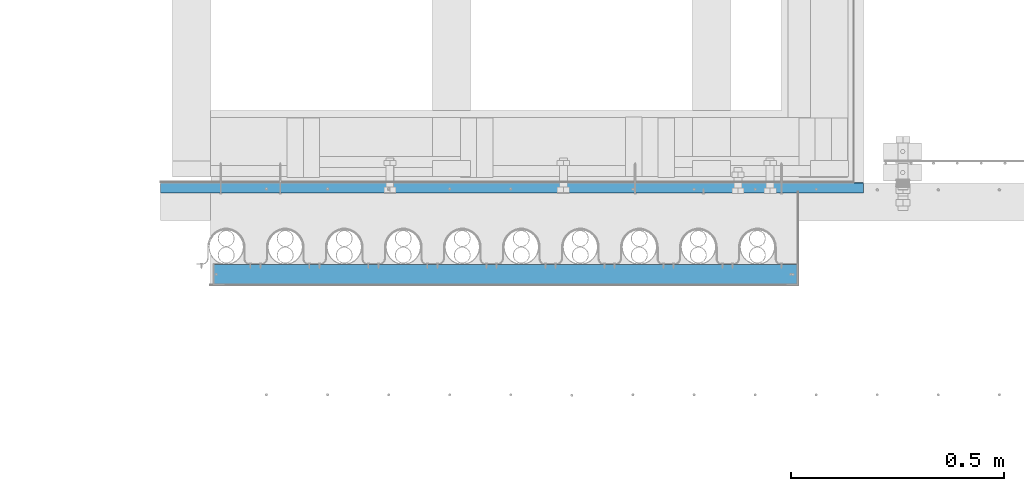
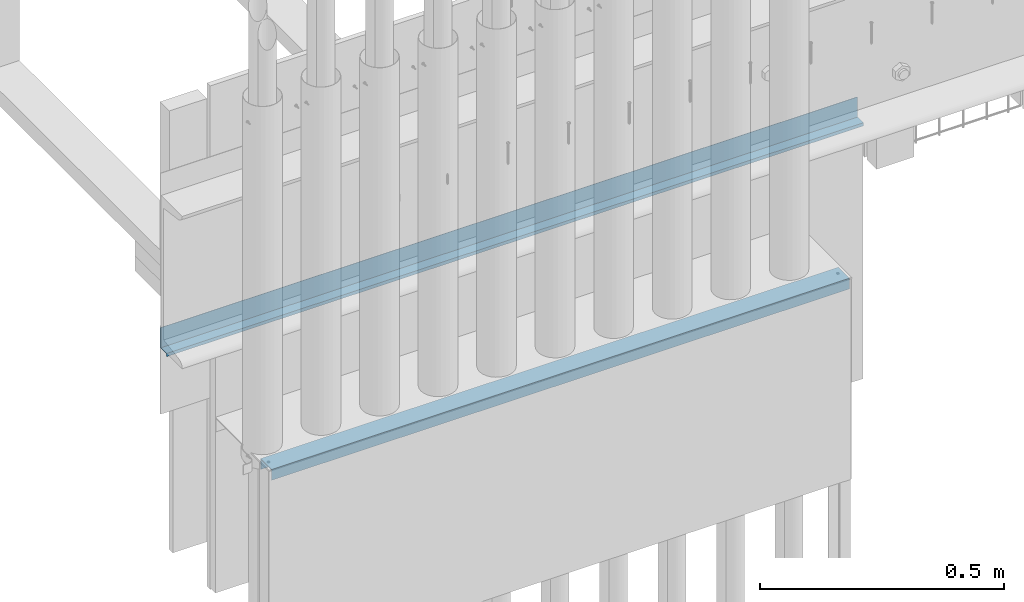
# One storey, part 5 of 44: 2 walls.
"""IFC4 building model written with IfcOpenShell, lengths in feet."""

from ifc_helpers import new_model, entity, si_unit, converted_unit, derived_unit, direction, frame, origin, place, context, subcontext, project, spatial, material, type_object, element, save


model = new_model("IFC4")

# Units and contexts
model_context = context("Model", 3, precision=0.0001, world=origin(), true_north=direction((6.12303176911189e-17, 1.0)))
body_context = subcontext(model_context, "Body", "Model", "MODEL_VIEW")
ifc_project = project(units=[converted_unit("LENGTHUNIT", "FOOT", entity("IfcRatioMeasure", 0.3048), si_unit("LENGTHUNIT", "METRE"), dimensions=[1, 0, 0, 0, 0, 0, 0]), converted_unit("AREAUNIT", "SQUARE FOOT", entity("IfcRatioMeasure", 0.09290304), si_unit("AREAUNIT", "SQUARE_METRE"), dimensions=[2, 0, 0, 0, 0, 0, 0]), converted_unit("VOLUMEUNIT", "CUBIC FOOT", entity("IfcRatioMeasure", 0.028316846592), si_unit("VOLUMEUNIT", "CUBIC_METRE"), dimensions=[3, 0, 0, 0, 0, 0, 0]), converted_unit("PLANEANGLEUNIT", "DEGREE", entity("IfcRatioMeasure", 0.0174532925199433), si_unit("PLANEANGLEUNIT", "RADIAN"), dimensions=[0, 0, 0, 0, 0, 0, 0]), si_unit("MASSUNIT", "GRAM", prefix="KILO"), derived_unit("MASSDENSITYUNIT", [(si_unit("MASSUNIT", "GRAM", prefix="KILO"), 1), (si_unit("LENGTHUNIT", "METRE"), -3)]), derived_unit("MOMENTOFINERTIAUNIT", [(si_unit("LENGTHUNIT", "METRE"), 4)]), si_unit("TIMEUNIT", "SECOND"), si_unit("FREQUENCYUNIT", "HERTZ"), si_unit("THERMODYNAMICTEMPERATUREUNIT", "DEGREE_CELSIUS"), derived_unit("THERMALTRANSMITTANCEUNIT", [(si_unit("MASSUNIT", "GRAM", prefix="KILO"), 1), (si_unit("THERMODYNAMICTEMPERATUREUNIT", "KELVIN"), -1), (si_unit("TIMEUNIT", "SECOND"), -3)]), derived_unit("VOLUMETRICFLOWRATEUNIT", [(si_unit("LENGTHUNIT", "METRE"), 3), (si_unit("TIMEUNIT", "SECOND"), -1)]), si_unit("ELECTRICCURRENTUNIT", "AMPERE"), si_unit("ELECTRICVOLTAGEUNIT", "VOLT"), si_unit("POWERUNIT", "WATT"), si_unit("FORCEUNIT", "NEWTON"), si_unit("ILLUMINANCEUNIT", "LUX"), si_unit("LUMINOUSFLUXUNIT", "LUMEN"), si_unit("LUMINOUSINTENSITYUNIT", "CANDELA"), derived_unit("USERDEFINED", [(si_unit("MASSUNIT", "GRAM", prefix="KILO"), -1), (si_unit("LENGTHUNIT", "METRE"), -2), (si_unit("TIMEUNIT", "SECOND"), 3), (si_unit("LUMINOUSFLUXUNIT", "LUMEN"), 1)]), derived_unit("LINEARVELOCITYUNIT", [(si_unit("LENGTHUNIT", "METRE"), 1), (si_unit("TIMEUNIT", "SECOND"), -1)]), si_unit("PRESSUREUNIT", "PASCAL"), derived_unit("USERDEFINED", [(si_unit("LENGTHUNIT", "METRE"), -2), (si_unit("MASSUNIT", "GRAM", prefix="KILO"), 1), (si_unit("TIMEUNIT", "SECOND"), -2)]), derived_unit("LINEARFORCEUNIT", [(si_unit("MASSUNIT", "GRAM", prefix="KILO"), 1), (si_unit("LENGTHUNIT", "METRE"), 1), (si_unit("TIMEUNIT", "SECOND"), -2), (si_unit("LENGTHUNIT", "METRE"), -1)]), derived_unit("PLANARFORCEUNIT", [(si_unit("MASSUNIT", "GRAM", prefix="KILO"), 1), (si_unit("LENGTHUNIT", "METRE"), 1), (si_unit("TIMEUNIT", "SECOND"), -2), (si_unit("LENGTHUNIT", "METRE"), -2)])], contexts=[model_context])

# Site, building, storey
site_placement = place(None, origin())
site = spatial("IfcSite", under=ifc_project, at=site_placement, CompositionType="ELEMENT")
building_placement = place(site_placement, origin())
building = spatial("IfcBuilding", under=site, at=building_placement, CompositionType="ELEMENT")
storey_placement = place(building_placement, origin())
storey = spatial("IfcBuildingStorey", under=building, at=storey_placement, CompositionType="ELEMENT", Elevation=0.0)

# Walls
ifc_material_1 = material(Name="METAL FLASHING - BLACK", Category="Materials")
wall_type_1 = type_object("IfcWallType", Name="Generic Models 747:Generic Models 1", PredefinedType="NOTDEFINED", material=ifc_material_1)
wall_1_placement = place(storey_placement, frame((1486.94745796881, 4.66458893176837, 8.64332690360264)))
cartesian_point_1 = entity("IfcCartesianPoint", [5.40549891969204, 0.0817969393312863, 0.0233852536726058])
vertex_point_1 = entity("IfcVertexPoint", cartesian_point_1)
cartesian_point_2 = entity("IfcCartesianPoint", [5.40549891969204, 0.0817969393312863, 0.191305214333033])
vertex_point_2 = entity("IfcVertexPoint", cartesian_point_2)
ifc_direction_1 = entity("IfcDirection", [0.0, 0.0, 1.0])
edge_curve_1 = entity("IfcEdgeCurve", vertex_point_1, vertex_point_2, entity("IfcTrimmedCurve", entity("IfcLine", cartesian_point_1, entity("IfcVector", ifc_direction_1, 1.0)), [cartesian_point_1], [cartesian_point_2], True, "CARTESIAN"), True)
cartesian_point_3 = entity("IfcCartesianPoint", [5.40549891969204, 0.0785417309979533, 0.191305214333035])
vertex_point_3 = entity("IfcVertexPoint", cartesian_point_3)
ifc_direction_2 = entity("IfcDirection", [0.0, -1.0, 0.0])
edge_curve_2 = entity("IfcEdgeCurve", vertex_point_2, vertex_point_3, entity("IfcTrimmedCurve", entity("IfcLine", cartesian_point_2, entity("IfcVector", ifc_direction_2, 1.0)), [cartesian_point_2], [cartesian_point_3], True, "CARTESIAN"), True)
cartesian_point_4 = entity("IfcCartesianPoint", [5.40549891969204, 0.0785417309979533, 0.0266404620059415])
vertex_point_4 = entity("IfcVertexPoint", cartesian_point_4)
ifc_direction_3 = entity("IfcDirection", [0.0, 0.0, -1.0])
edge_curve_3 = entity("IfcEdgeCurve", vertex_point_3, vertex_point_4, entity("IfcTrimmedCurve", entity("IfcLine", cartesian_point_3, entity("IfcVector", ifc_direction_3, 1.0)), [cartesian_point_3], [cartesian_point_4], True, "CARTESIAN"), True)
cartesian_point_5 = entity("IfcCartesianPoint", [5.40549891969204, 0.00129654317320504, 0.0266404620059415])
vertex_point_5 = entity("IfcVertexPoint", cartesian_point_5)
edge_curve_4 = entity("IfcEdgeCurve", vertex_point_4, vertex_point_5, entity("IfcTrimmedCurve", entity("IfcLine", cartesian_point_4, entity("IfcVector", ifc_direction_2, 1.0)), [cartesian_point_4], [cartesian_point_5], True, "CARTESIAN"), True)
cartesian_point_6 = entity("IfcCartesianPoint", [5.40549891969204, 0.00129654317320504, 0.0])
vertex_point_6 = entity("IfcVertexPoint", cartesian_point_6)
cartesian_point_7 = entity("IfcCartesianPoint", [5.40549891969204, 0.0690719683980001, 0.0133202310029716])
ifc_direction_4 = entity("IfcDirection", [1.0, 0.0, 0.0])
edge_curve_5 = entity("IfcEdgeCurve", vertex_point_5, vertex_point_6, entity("IfcTrimmedCurve", entity("IfcCircle", entity("IfcAxis2Placement3D", cartesian_point_7, ifc_direction_4, ifc_direction_2), 0.069071968398), [cartesian_point_5], [cartesian_point_6], True, "CARTESIAN"), True)
cartesian_point_8 = entity("IfcCartesianPoint", [5.40549891969204, 0.00450293920002309, 0.000565374130363949])
vertex_point_7 = entity("IfcVertexPoint", cartesian_point_8)
edge_curve_6 = entity("IfcEdgeCurve", vertex_point_6, vertex_point_7, entity("IfcTrimmedCurve", entity("IfcLine", cartesian_point_6, entity("IfcVector", entity("IfcDirection", [0.0, 0.984807753012234, 0.173648177666783]), 1.0)), [cartesian_point_6], [cartesian_point_8], True, "CARTESIAN"), True)
cartesian_point_9 = entity("IfcCartesianPoint", [5.40549891969204, 0.00402935756425826, 0.0233852536726076])
vertex_point_8 = entity("IfcVertexPoint", cartesian_point_9)
ifc_direction_5 = entity("IfcDirection", [-1.0, 0.0, 0.0])
edge_curve_7 = entity("IfcEdgeCurve", vertex_point_7, vertex_point_8, entity("IfcTrimmedCurve", entity("IfcCircle", entity("IfcAxis2Placement3D", cartesian_point_7, ifc_direction_5, ifc_direction_2), 0.0658167600646667), [cartesian_point_8], [cartesian_point_9], True, "CARTESIAN"), True)
ifc_direction_6 = entity("IfcDirection", [0.0, 1.0, 0.0])
edge_curve_8 = entity("IfcEdgeCurve", vertex_point_8, vertex_point_1, entity("IfcTrimmedCurve", entity("IfcLine", cartesian_point_9, entity("IfcVector", ifc_direction_6, 1.0)), [cartesian_point_9], [cartesian_point_1], True, "CARTESIAN"), True)
cartesian_point_10 = entity("IfcCartesianPoint", [0.0, 0.081796939331376, 0.0233852536726165])
vertex_point_9 = entity("IfcVertexPoint", cartesian_point_10)
cartesian_point_11 = entity("IfcCartesianPoint", [0.0, 0.00402935756434797, 0.0233852536726165])
vertex_point_10 = entity("IfcVertexPoint", cartesian_point_11)
edge_curve_9 = entity("IfcEdgeCurve", vertex_point_9, vertex_point_10, entity("IfcTrimmedCurve", entity("IfcLine", cartesian_point_10, entity("IfcVector", ifc_direction_2, 1.0)), [cartesian_point_10], [cartesian_point_11], True, "CARTESIAN"), True)
cartesian_point_12 = entity("IfcCartesianPoint", [0.0, 0.0045029392001128, 0.000565374130372831])
vertex_point_11 = entity("IfcVertexPoint", cartesian_point_12)
cartesian_point_13 = entity("IfcCartesianPoint", [0.0, 0.0690719683980898, 0.0133202310029805])
edge_curve_10 = entity("IfcEdgeCurve", vertex_point_10, vertex_point_11, entity("IfcTrimmedCurve", entity("IfcCircle", entity("IfcAxis2Placement3D", cartesian_point_13, ifc_direction_4, ifc_direction_2), 0.0658167600646667), [cartesian_point_11], [cartesian_point_12], True, "CARTESIAN"), True)
cartesian_point_14 = entity("IfcCartesianPoint", [0.0, 0.00129654317329475, 0.0])
vertex_point_12 = entity("IfcVertexPoint", cartesian_point_14)
edge_curve_11 = entity("IfcEdgeCurve", vertex_point_11, vertex_point_12, entity("IfcTrimmedCurve", entity("IfcLine", cartesian_point_12, entity("IfcVector", entity("IfcDirection", [0.0, -0.984807753012234, -0.173648177666783]), 1.0)), [cartesian_point_12], [cartesian_point_14], True, "CARTESIAN"), True)
cartesian_point_15 = entity("IfcCartesianPoint", [0.0, 0.00129654317329475, 0.0266404620059504])
vertex_point_13 = entity("IfcVertexPoint", cartesian_point_15)
edge_curve_12 = entity("IfcEdgeCurve", vertex_point_12, vertex_point_13, entity("IfcTrimmedCurve", entity("IfcCircle", entity("IfcAxis2Placement3D", cartesian_point_13, ifc_direction_5, ifc_direction_2), 0.069071968398), [cartesian_point_14], [cartesian_point_15], True, "CARTESIAN"), True)
cartesian_point_16 = entity("IfcCartesianPoint", [0.0, 0.078541730998043, 0.0266404620059504])
vertex_point_14 = entity("IfcVertexPoint", cartesian_point_16)
edge_curve_13 = entity("IfcEdgeCurve", vertex_point_13, vertex_point_14, entity("IfcTrimmedCurve", entity("IfcLine", cartesian_point_15, entity("IfcVector", ifc_direction_6, 1.0)), [cartesian_point_15], [cartesian_point_16], True, "CARTESIAN"), True)
cartesian_point_17 = entity("IfcCartesianPoint", [0.0, 0.078541730998043, 0.191305214333042])
vertex_point_15 = entity("IfcVertexPoint", cartesian_point_17)
edge_curve_14 = entity("IfcEdgeCurve", vertex_point_14, vertex_point_15, entity("IfcTrimmedCurve", entity("IfcLine", cartesian_point_16, entity("IfcVector", ifc_direction_1, 1.0)), [cartesian_point_16], [cartesian_point_17], True, "CARTESIAN"), True)
cartesian_point_18 = entity("IfcCartesianPoint", [0.0, 0.081796939331376, 0.191305214333044])
vertex_point_16 = entity("IfcVertexPoint", cartesian_point_18)
edge_curve_15 = entity("IfcEdgeCurve", vertex_point_15, vertex_point_16, entity("IfcTrimmedCurve", entity("IfcLine", cartesian_point_17, entity("IfcVector", ifc_direction_6, 1.0)), [cartesian_point_17], [cartesian_point_18], True, "CARTESIAN"), True)
edge_curve_16 = entity("IfcEdgeCurve", vertex_point_16, vertex_point_9, entity("IfcTrimmedCurve", entity("IfcLine", cartesian_point_18, entity("IfcVector", ifc_direction_3, 1.0)), [cartesian_point_18], [cartesian_point_10], True, "CARTESIAN"), True)
edge_curve_17 = entity("IfcEdgeCurve", vertex_point_9, vertex_point_1, entity("IfcTrimmedCurve", entity("IfcLine", cartesian_point_10, entity("IfcVector", ifc_direction_4, 1.0)), [cartesian_point_10], [cartesian_point_1], True, "CARTESIAN"), True)
edge_curve_18 = entity("IfcEdgeCurve", vertex_point_8, vertex_point_10, entity("IfcTrimmedCurve", entity("IfcLine", cartesian_point_11, entity("IfcVector", ifc_direction_5, 1.0)), [cartesian_point_9], [cartesian_point_11], True, "CARTESIAN"), True)
edge_curve_19 = entity("IfcEdgeCurve", vertex_point_13, vertex_point_5, entity("IfcTrimmedCurve", entity("IfcLine", cartesian_point_15, entity("IfcVector", ifc_direction_4, 1.0)), [cartesian_point_15], [cartesian_point_5], True, "CARTESIAN"), True)
edge_curve_20 = entity("IfcEdgeCurve", vertex_point_4, vertex_point_14, entity("IfcTrimmedCurve", entity("IfcLine", cartesian_point_16, entity("IfcVector", ifc_direction_5, 1.0)), [cartesian_point_4], [cartesian_point_16], True, "CARTESIAN"), True)
edge_curve_21 = entity("IfcEdgeCurve", vertex_point_3, vertex_point_15, entity("IfcTrimmedCurve", entity("IfcLine", cartesian_point_17, entity("IfcVector", ifc_direction_5, 1.0)), [cartesian_point_3], [cartesian_point_17], True, "CARTESIAN"), True)
edge_curve_22 = entity("IfcEdgeCurve", vertex_point_2, vertex_point_16, entity("IfcTrimmedCurve", entity("IfcLine", cartesian_point_18, entity("IfcVector", ifc_direction_5, 1.0)), [cartesian_point_2], [cartesian_point_18], True, "CARTESIAN"), True)
edge_curve_23 = entity("IfcEdgeCurve", vertex_point_11, vertex_point_7, entity("IfcTrimmedCurve", entity("IfcLine", cartesian_point_12, entity("IfcVector", ifc_direction_4, 1.0)), [cartesian_point_12], [cartesian_point_8], True, "CARTESIAN"), True)
edge_curve_24 = entity("IfcEdgeCurve", vertex_point_6, vertex_point_12, entity("IfcTrimmedCurve", entity("IfcLine", cartesian_point_14, entity("IfcVector", ifc_direction_5, 1.0)), [cartesian_point_6], [cartesian_point_14], True, "CARTESIAN"), True)
element("IfcWall", 1, at=wall_1_placement, inside=storey, type_object=wall_type_1, material=ifc_material_1, Name="Generic Models 747:Generic Models 1", ObjectType="Generic Models 747:Generic Models 1", PredefinedType="NOTDEFINED", context=body_context, shape_type="AdvancedBrep", body=[
    entity("IfcAdvancedBrep", entity("IfcClosedShell", [entity("IfcAdvancedFace", [entity("IfcFaceOuterBound", entity("IfcEdgeLoop", [entity("IfcOrientedEdge", None, None, edge_curve_1, True), entity("IfcOrientedEdge", None, None, edge_curve_2, True), entity("IfcOrientedEdge", None, None, edge_curve_3, True), entity("IfcOrientedEdge", None, None, edge_curve_4, True), entity("IfcOrientedEdge", None, None, edge_curve_5, True), entity("IfcOrientedEdge", None, None, edge_curve_6, True), entity("IfcOrientedEdge", None, None, edge_curve_7, True), entity("IfcOrientedEdge", None, None, edge_curve_8, True)]), True)], entity("IfcPlane", entity("IfcAxis2Placement3D", entity("IfcCartesianPoint", [5.40549891969204, -0.0484690976190674, 0.0233852536726076]), ifc_direction_4, ifc_direction_6)), True), entity("IfcAdvancedFace", [entity("IfcFaceOuterBound", entity("IfcEdgeLoop", [entity("IfcOrientedEdge", None, None, edge_curve_9, True), entity("IfcOrientedEdge", None, None, edge_curve_10, True), entity("IfcOrientedEdge", None, None, edge_curve_11, True), entity("IfcOrientedEdge", None, None, edge_curve_12, True), entity("IfcOrientedEdge", None, None, edge_curve_13, True), entity("IfcOrientedEdge", None, None, edge_curve_14, True), entity("IfcOrientedEdge", None, None, edge_curve_15, True), entity("IfcOrientedEdge", None, None, edge_curve_16, True)]), True)], entity("IfcPlane", entity("IfcAxis2Placement3D", entity("IfcCartesianPoint", [0.0, -0.0484690976189777, 0.0233852536726165]), ifc_direction_5, ifc_direction_2)), True), entity("IfcAdvancedFace", [entity("IfcFaceOuterBound", entity("IfcEdgeLoop", [entity("IfcOrientedEdge", None, None, edge_curve_9, False), entity("IfcOrientedEdge", None, None, edge_curve_17, True), entity("IfcOrientedEdge", None, None, edge_curve_8, False), entity("IfcOrientedEdge", None, None, edge_curve_18, True)]), True)], entity("IfcPlane", entity("IfcAxis2Placement3D", cartesian_point_10, ifc_direction_3, ifc_direction_4)), True), entity("IfcAdvancedFace", [entity("IfcFaceOuterBound", entity("IfcEdgeLoop", [entity("IfcOrientedEdge", None, None, edge_curve_13, False), entity("IfcOrientedEdge", None, None, edge_curve_19, True), entity("IfcOrientedEdge", None, None, edge_curve_4, False), entity("IfcOrientedEdge", None, None, edge_curve_20, True)]), True)], entity("IfcPlane", entity("IfcAxis2Placement3D", cartesian_point_15, ifc_direction_1, ifc_direction_4)), True), entity("IfcAdvancedFace", [entity("IfcFaceOuterBound", entity("IfcEdgeLoop", [entity("IfcOrientedEdge", None, None, edge_curve_14, False), entity("IfcOrientedEdge", None, None, edge_curve_20, False), entity("IfcOrientedEdge", None, None, edge_curve_3, False), entity("IfcOrientedEdge", None, None, edge_curve_21, True)]), True)], entity("IfcPlane", entity("IfcAxis2Placement3D", cartesian_point_16, ifc_direction_2, ifc_direction_4)), True), entity("IfcAdvancedFace", [entity("IfcFaceOuterBound", entity("IfcEdgeLoop", [entity("IfcOrientedEdge", None, None, edge_curve_15, False), entity("IfcOrientedEdge", None, None, edge_curve_21, False), entity("IfcOrientedEdge", None, None, edge_curve_2, False), entity("IfcOrientedEdge", None, None, edge_curve_22, True)]), True)], entity("IfcPlane", entity("IfcAxis2Placement3D", cartesian_point_17, ifc_direction_1, ifc_direction_4)), True), entity("IfcAdvancedFace", [entity("IfcFaceOuterBound", entity("IfcEdgeLoop", [entity("IfcOrientedEdge", None, None, edge_curve_16, False), entity("IfcOrientedEdge", None, None, edge_curve_22, False), entity("IfcOrientedEdge", None, None, edge_curve_1, False), entity("IfcOrientedEdge", None, None, edge_curve_17, False)]), True)], entity("IfcPlane", entity("IfcAxis2Placement3D", cartesian_point_18, ifc_direction_6, ifc_direction_4)), True), entity("IfcAdvancedFace", [entity("IfcFaceOuterBound", entity("IfcEdgeLoop", [entity("IfcOrientedEdge", None, None, edge_curve_11, False), entity("IfcOrientedEdge", None, None, edge_curve_23, True), entity("IfcOrientedEdge", None, None, edge_curve_6, False), entity("IfcOrientedEdge", None, None, edge_curve_24, True)]), True)], entity("IfcPlane", entity("IfcAxis2Placement3D", cartesian_point_12, entity("IfcDirection", [0.0, 0.173648177666783, -0.984807753012234]), ifc_direction_4)), True), entity("IfcAdvancedFace", [entity("IfcFaceOuterBound", entity("IfcEdgeLoop", [entity("IfcOrientedEdge", None, None, edge_curve_10, False), entity("IfcOrientedEdge", None, None, edge_curve_18, False), entity("IfcOrientedEdge", None, None, edge_curve_7, False), entity("IfcOrientedEdge", None, None, edge_curve_23, False)]), True)], entity("IfcCylindricalSurface", entity("IfcAxis2Placement3D", cartesian_point_7, ifc_direction_4, ifc_direction_2), 0.0658167600646667), False), entity("IfcAdvancedFace", [entity("IfcFaceOuterBound", entity("IfcEdgeLoop", [entity("IfcOrientedEdge", None, None, edge_curve_12, False), entity("IfcOrientedEdge", None, None, edge_curve_24, False), entity("IfcOrientedEdge", None, None, edge_curve_5, False), entity("IfcOrientedEdge", None, None, edge_curve_19, False)]), True)], entity("IfcCylindricalSurface", entity("IfcAxis2Placement3D", cartesian_point_7, ifc_direction_5, ifc_direction_2), 0.069071968398), True)])),
])
ifc_material_2 = material(Name="GALV. METAL STUD - TOP TRACK", Category="Materials")
wall_type_2 = type_object("IfcWallType", Name="Metal stud5:Metal stud", PredefinedType="NOTDEFINED", material=ifc_material_2)
wall_2_placement = place(storey_placement, frame((1487.35885410766, 3.96511726984431, 7.91076832193818)))
cartesian_point_19 = entity("IfcCartesianPoint", [0.0, 0.151041666666732, 0.0872395833333286])
vertex_point_17 = entity("IfcVertexPoint", cartesian_point_19)
cartesian_point_20 = entity("IfcCartesianPoint", [0.0, 0.151041666666747, 0.0])
vertex_point_18 = entity("IfcVertexPoint", cartesian_point_20)
ifc_direction_7 = entity("IfcDirection", [0.0, 0.0, -1.0])
edge_curve_25 = entity("IfcEdgeCurve", vertex_point_17, vertex_point_18, entity("IfcTrimmedCurve", entity("IfcLine", cartesian_point_19, entity("IfcVector", ifc_direction_7, 1.0)), [cartesian_point_19], [cartesian_point_20], True, "CARTESIAN"), True)
cartesian_point_21 = entity("IfcCartesianPoint", [0.0, 0.145833333333414, 0.0])
vertex_point_19 = entity("IfcVertexPoint", cartesian_point_21)
ifc_direction_8 = entity("IfcDirection", [0.0, -1.0, 0.0])
edge_curve_26 = entity("IfcEdgeCurve", vertex_point_18, vertex_point_19, entity("IfcTrimmedCurve", entity("IfcLine", cartesian_point_20, entity("IfcVector", ifc_direction_8, 1.0)), [cartesian_point_20], [cartesian_point_21], True, "CARTESIAN"), True)
cartesian_point_22 = entity("IfcCartesianPoint", [0.0, 0.1458333333334, 0.0820312499999947])
vertex_point_20 = entity("IfcVertexPoint", cartesian_point_22)
ifc_direction_9 = entity("IfcDirection", [0.0, 0.0, 1.0])
edge_curve_27 = entity("IfcEdgeCurve", vertex_point_19, vertex_point_20, entity("IfcTrimmedCurve", entity("IfcLine", cartesian_point_21, entity("IfcVector", ifc_direction_9, 1.0)), [cartesian_point_21], [cartesian_point_22], True, "CARTESIAN"), True)
cartesian_point_23 = entity("IfcCartesianPoint", [0.0, 0.00520833333333437, 0.082031249999968])
vertex_point_21 = entity("IfcVertexPoint", cartesian_point_23)
edge_curve_28 = entity("IfcEdgeCurve", vertex_point_20, vertex_point_21, entity("IfcTrimmedCurve", entity("IfcLine", cartesian_point_22, entity("IfcVector", ifc_direction_8, 1.0)), [cartesian_point_22], [cartesian_point_23], True, "CARTESIAN"), True)
cartesian_point_24 = entity("IfcCartesianPoint", [0.0, 0.00520833333334902, 0.0])
vertex_point_22 = entity("IfcVertexPoint", cartesian_point_24)
edge_curve_29 = entity("IfcEdgeCurve", vertex_point_21, vertex_point_22, entity("IfcTrimmedCurve", entity("IfcLine", cartesian_point_23, entity("IfcVector", ifc_direction_7, 1.0)), [cartesian_point_23], [cartesian_point_24], True, "CARTESIAN"), True)
cartesian_point_25 = entity("IfcCartesianPoint", [0.0, 0.0, 0.0])
vertex_point_23 = entity("IfcVertexPoint", cartesian_point_25)
edge_curve_30 = entity("IfcEdgeCurve", vertex_point_22, vertex_point_23, entity("IfcTrimmedCurve", entity("IfcLine", cartesian_point_24, entity("IfcVector", ifc_direction_8, 1.0)), [cartesian_point_24], [cartesian_point_25], True, "CARTESIAN"), True)
cartesian_point_26 = entity("IfcCartesianPoint", [0.0, 0.0, 0.087239583333302])
vertex_point_24 = entity("IfcVertexPoint", cartesian_point_26)
edge_curve_31 = entity("IfcEdgeCurve", vertex_point_23, vertex_point_24, entity("IfcTrimmedCurve", entity("IfcLine", cartesian_point_25, entity("IfcVector", ifc_direction_9, 1.0)), [cartesian_point_25], [cartesian_point_26], True, "CARTESIAN"), True)
ifc_direction_10 = entity("IfcDirection", [0.0, 1.0, 0.0])
edge_curve_32 = entity("IfcEdgeCurve", vertex_point_24, vertex_point_17, entity("IfcTrimmedCurve", entity("IfcLine", cartesian_point_26, entity("IfcVector", ifc_direction_10, 1.0)), [cartesian_point_26], [cartesian_point_19], True, "CARTESIAN"), True)
ifc_direction_11 = entity("IfcDirection", [-1.0, 0.0, 0.0])
cartesian_point_27 = entity("IfcCartesianPoint", [4.48350251565967, 0.151041666666732, 0.0872395833333286])
vertex_point_25 = entity("IfcVertexPoint", cartesian_point_27)
cartesian_point_28 = entity("IfcCartesianPoint", [4.48350251565967, 0.0, 0.087239583333302])
vertex_point_26 = entity("IfcVertexPoint", cartesian_point_28)
edge_curve_33 = entity("IfcEdgeCurve", vertex_point_25, vertex_point_26, entity("IfcTrimmedCurve", entity("IfcLine", cartesian_point_27, entity("IfcVector", ifc_direction_8, 1.0)), [cartesian_point_27], [cartesian_point_28], True, "CARTESIAN"), True)
cartesian_point_29 = entity("IfcCartesianPoint", [4.48350251565967, 0.0, 0.0])
vertex_point_27 = entity("IfcVertexPoint", cartesian_point_29)
edge_curve_34 = entity("IfcEdgeCurve", vertex_point_26, vertex_point_27, entity("IfcTrimmedCurve", entity("IfcLine", cartesian_point_28, entity("IfcVector", ifc_direction_7, 1.0)), [cartesian_point_28], [cartesian_point_29], True, "CARTESIAN"), True)
cartesian_point_30 = entity("IfcCartesianPoint", [4.48350251565967, 0.00520833333334902, 0.0])
vertex_point_28 = entity("IfcVertexPoint", cartesian_point_30)
edge_curve_35 = entity("IfcEdgeCurve", vertex_point_27, vertex_point_28, entity("IfcTrimmedCurve", entity("IfcLine", cartesian_point_29, entity("IfcVector", ifc_direction_10, 1.0)), [cartesian_point_29], [cartesian_point_30], True, "CARTESIAN"), True)
cartesian_point_31 = entity("IfcCartesianPoint", [4.48350251565967, 0.00520833333333437, 0.082031249999968])
vertex_point_29 = entity("IfcVertexPoint", cartesian_point_31)
edge_curve_36 = entity("IfcEdgeCurve", vertex_point_28, vertex_point_29, entity("IfcTrimmedCurve", entity("IfcLine", cartesian_point_30, entity("IfcVector", ifc_direction_9, 1.0)), [cartesian_point_30], [cartesian_point_31], True, "CARTESIAN"), True)
cartesian_point_32 = entity("IfcCartesianPoint", [4.48350251565967, 0.1458333333334, 0.0820312499999947])
vertex_point_30 = entity("IfcVertexPoint", cartesian_point_32)
edge_curve_37 = entity("IfcEdgeCurve", vertex_point_29, vertex_point_30, entity("IfcTrimmedCurve", entity("IfcLine", cartesian_point_31, entity("IfcVector", ifc_direction_10, 1.0)), [cartesian_point_31], [cartesian_point_32], True, "CARTESIAN"), True)
cartesian_point_33 = entity("IfcCartesianPoint", [4.48350251565967, 0.145833333333414, 0.0])
vertex_point_31 = entity("IfcVertexPoint", cartesian_point_33)
edge_curve_38 = entity("IfcEdgeCurve", vertex_point_30, vertex_point_31, entity("IfcTrimmedCurve", entity("IfcLine", cartesian_point_32, entity("IfcVector", ifc_direction_7, 1.0)), [cartesian_point_32], [cartesian_point_33], True, "CARTESIAN"), True)
cartesian_point_34 = entity("IfcCartesianPoint", [4.48350251565967, 0.151041666666747, 0.0])
vertex_point_32 = entity("IfcVertexPoint", cartesian_point_34)
edge_curve_39 = entity("IfcEdgeCurve", vertex_point_31, vertex_point_32, entity("IfcTrimmedCurve", entity("IfcLine", cartesian_point_33, entity("IfcVector", ifc_direction_10, 1.0)), [cartesian_point_33], [cartesian_point_34], True, "CARTESIAN"), True)
edge_curve_40 = entity("IfcEdgeCurve", vertex_point_32, vertex_point_25, entity("IfcTrimmedCurve", entity("IfcLine", cartesian_point_34, entity("IfcVector", ifc_direction_9, 1.0)), [cartesian_point_34], [cartesian_point_27], True, "CARTESIAN"), True)
ifc_direction_12 = entity("IfcDirection", [1.0, 0.0, 0.0])
edge_curve_41 = entity("IfcEdgeCurve", vertex_point_24, vertex_point_26, entity("IfcTrimmedCurve", entity("IfcLine", cartesian_point_26, entity("IfcVector", ifc_direction_12, 1.0)), [cartesian_point_26], [cartesian_point_28], True, "CARTESIAN"), True)
edge_curve_42 = entity("IfcEdgeCurve", vertex_point_25, vertex_point_17, entity("IfcTrimmedCurve", entity("IfcLine", cartesian_point_19, entity("IfcVector", ifc_direction_11, 1.0)), [cartesian_point_27], [cartesian_point_19], True, "CARTESIAN"), True)
edge_curve_43 = entity("IfcEdgeCurve", vertex_point_23, vertex_point_27, entity("IfcTrimmedCurve", entity("IfcLine", cartesian_point_25, entity("IfcVector", ifc_direction_12, 1.0)), [cartesian_point_25], [cartesian_point_29], True, "CARTESIAN"), True)
edge_curve_44 = entity("IfcEdgeCurve", vertex_point_32, vertex_point_18, entity("IfcTrimmedCurve", entity("IfcLine", cartesian_point_20, entity("IfcVector", ifc_direction_11, 1.0)), [cartesian_point_34], [cartesian_point_20], True, "CARTESIAN"), True)
edge_curve_45 = entity("IfcEdgeCurve", vertex_point_22, vertex_point_28, entity("IfcTrimmedCurve", entity("IfcLine", cartesian_point_24, entity("IfcVector", ifc_direction_12, 1.0)), [cartesian_point_24], [cartesian_point_30], True, "CARTESIAN"), True)
edge_curve_46 = entity("IfcEdgeCurve", vertex_point_31, vertex_point_19, entity("IfcTrimmedCurve", entity("IfcLine", cartesian_point_21, entity("IfcVector", ifc_direction_11, 1.0)), [cartesian_point_33], [cartesian_point_21], True, "CARTESIAN"), True)
edge_curve_47 = entity("IfcEdgeCurve", vertex_point_21, vertex_point_29, entity("IfcTrimmedCurve", entity("IfcLine", cartesian_point_23, entity("IfcVector", ifc_direction_12, 1.0)), [cartesian_point_23], [cartesian_point_31], True, "CARTESIAN"), True)
edge_curve_48 = entity("IfcEdgeCurve", vertex_point_20, vertex_point_30, entity("IfcTrimmedCurve", entity("IfcLine", cartesian_point_22, entity("IfcVector", ifc_direction_12, 1.0)), [cartesian_point_22], [cartesian_point_32], True, "CARTESIAN"), True)
element("IfcWall", 2, at=wall_2_placement, inside=storey, type_object=wall_type_2, material=ifc_material_2, Name="Metal stud5:Metal stud", ObjectType="Metal stud5:Metal stud", PredefinedType="NOTDEFINED", context=body_context, shape_type="AdvancedBrep", body=[
    entity("IfcAdvancedBrep", entity("IfcClosedShell", [entity("IfcAdvancedFace", [entity("IfcFaceOuterBound", entity("IfcEdgeLoop", [entity("IfcOrientedEdge", None, None, edge_curve_25, True), entity("IfcOrientedEdge", None, None, edge_curve_26, True), entity("IfcOrientedEdge", None, None, edge_curve_27, True), entity("IfcOrientedEdge", None, None, edge_curve_28, True), entity("IfcOrientedEdge", None, None, edge_curve_29, True), entity("IfcOrientedEdge", None, None, edge_curve_30, True), entity("IfcOrientedEdge", None, None, edge_curve_31, True), entity("IfcOrientedEdge", None, None, edge_curve_32, True)]), True)], entity("IfcPlane", entity("IfcAxis2Placement3D", entity("IfcCartesianPoint", [0.0, 0.151041666666761, -0.0833333333334849]), ifc_direction_11, ifc_direction_7)), True), entity("IfcAdvancedFace", [entity("IfcFaceOuterBound", entity("IfcEdgeLoop", [entity("IfcOrientedEdge", None, None, edge_curve_33, True), entity("IfcOrientedEdge", None, None, edge_curve_34, True), entity("IfcOrientedEdge", None, None, edge_curve_35, True), entity("IfcOrientedEdge", None, None, edge_curve_36, True), entity("IfcOrientedEdge", None, None, edge_curve_37, True), entity("IfcOrientedEdge", None, None, edge_curve_38, True), entity("IfcOrientedEdge", None, None, edge_curve_39, True), entity("IfcOrientedEdge", None, None, edge_curve_40, True)]), True)], entity("IfcPlane", entity("IfcAxis2Placement3D", entity("IfcCartesianPoint", [4.48350251565967, 0.151041666666761, -0.0833333333334849]), ifc_direction_12, ifc_direction_9)), True), entity("IfcAdvancedFace", [entity("IfcFaceOuterBound", entity("IfcEdgeLoop", [entity("IfcOrientedEdge", None, None, edge_curve_32, False), entity("IfcOrientedEdge", None, None, edge_curve_41, True), entity("IfcOrientedEdge", None, None, edge_curve_33, False), entity("IfcOrientedEdge", None, None, edge_curve_42, True)]), True)], entity("IfcPlane", entity("IfcAxis2Placement3D", cartesian_point_26, ifc_direction_9, ifc_direction_12)), True), entity("IfcAdvancedFace", [entity("IfcFaceOuterBound", entity("IfcEdgeLoop", [entity("IfcOrientedEdge", None, None, edge_curve_31, False), entity("IfcOrientedEdge", None, None, edge_curve_43, True), entity("IfcOrientedEdge", None, None, edge_curve_34, False), entity("IfcOrientedEdge", None, None, edge_curve_41, False)]), True)], entity("IfcPlane", entity("IfcAxis2Placement3D", cartesian_point_25, ifc_direction_8, ifc_direction_12)), True), entity("IfcAdvancedFace", [entity("IfcFaceOuterBound", entity("IfcEdgeLoop", [entity("IfcOrientedEdge", None, None, edge_curve_25, False), entity("IfcOrientedEdge", None, None, edge_curve_42, False), entity("IfcOrientedEdge", None, None, edge_curve_40, False), entity("IfcOrientedEdge", None, None, edge_curve_44, True)]), True)], entity("IfcPlane", entity("IfcAxis2Placement3D", cartesian_point_19, ifc_direction_10, ifc_direction_12)), True), entity("IfcAdvancedFace", [entity("IfcFaceOuterBound", entity("IfcEdgeLoop", [entity("IfcOrientedEdge", None, None, edge_curve_30, False), entity("IfcOrientedEdge", None, None, edge_curve_45, True), entity("IfcOrientedEdge", None, None, edge_curve_35, False), entity("IfcOrientedEdge", None, None, edge_curve_43, False)]), True)], entity("IfcPlane", entity("IfcAxis2Placement3D", cartesian_point_24, ifc_direction_7, ifc_direction_12)), True), entity("IfcAdvancedFace", [entity("IfcFaceOuterBound", entity("IfcEdgeLoop", [entity("IfcOrientedEdge", None, None, edge_curve_26, False), entity("IfcOrientedEdge", None, None, edge_curve_44, False), entity("IfcOrientedEdge", None, None, edge_curve_39, False), entity("IfcOrientedEdge", None, None, edge_curve_46, True)]), True)], entity("IfcPlane", entity("IfcAxis2Placement3D", cartesian_point_20, ifc_direction_7, ifc_direction_12)), True), entity("IfcAdvancedFace", [entity("IfcFaceOuterBound", entity("IfcEdgeLoop", [entity("IfcOrientedEdge", None, None, edge_curve_29, False), entity("IfcOrientedEdge", None, None, edge_curve_47, True), entity("IfcOrientedEdge", None, None, edge_curve_36, False), entity("IfcOrientedEdge", None, None, edge_curve_45, False)]), True)], entity("IfcPlane", entity("IfcAxis2Placement3D", cartesian_point_23, ifc_direction_10, ifc_direction_12)), True), entity("IfcAdvancedFace", [entity("IfcFaceOuterBound", entity("IfcEdgeLoop", [entity("IfcOrientedEdge", None, None, edge_curve_28, False), entity("IfcOrientedEdge", None, None, edge_curve_48, True), entity("IfcOrientedEdge", None, None, edge_curve_37, False), entity("IfcOrientedEdge", None, None, edge_curve_47, False)]), True)], entity("IfcPlane", entity("IfcAxis2Placement3D", cartesian_point_22, ifc_direction_7, ifc_direction_12)), True), entity("IfcAdvancedFace", [entity("IfcFaceOuterBound", entity("IfcEdgeLoop", [entity("IfcOrientedEdge", None, None, edge_curve_27, False), entity("IfcOrientedEdge", None, None, edge_curve_46, False), entity("IfcOrientedEdge", None, None, edge_curve_38, False), entity("IfcOrientedEdge", None, None, edge_curve_48, False)]), True)], entity("IfcPlane", entity("IfcAxis2Placement3D", cartesian_point_21, ifc_direction_8, ifc_direction_12)), True)])),
])

save(model, "model.ifc")
